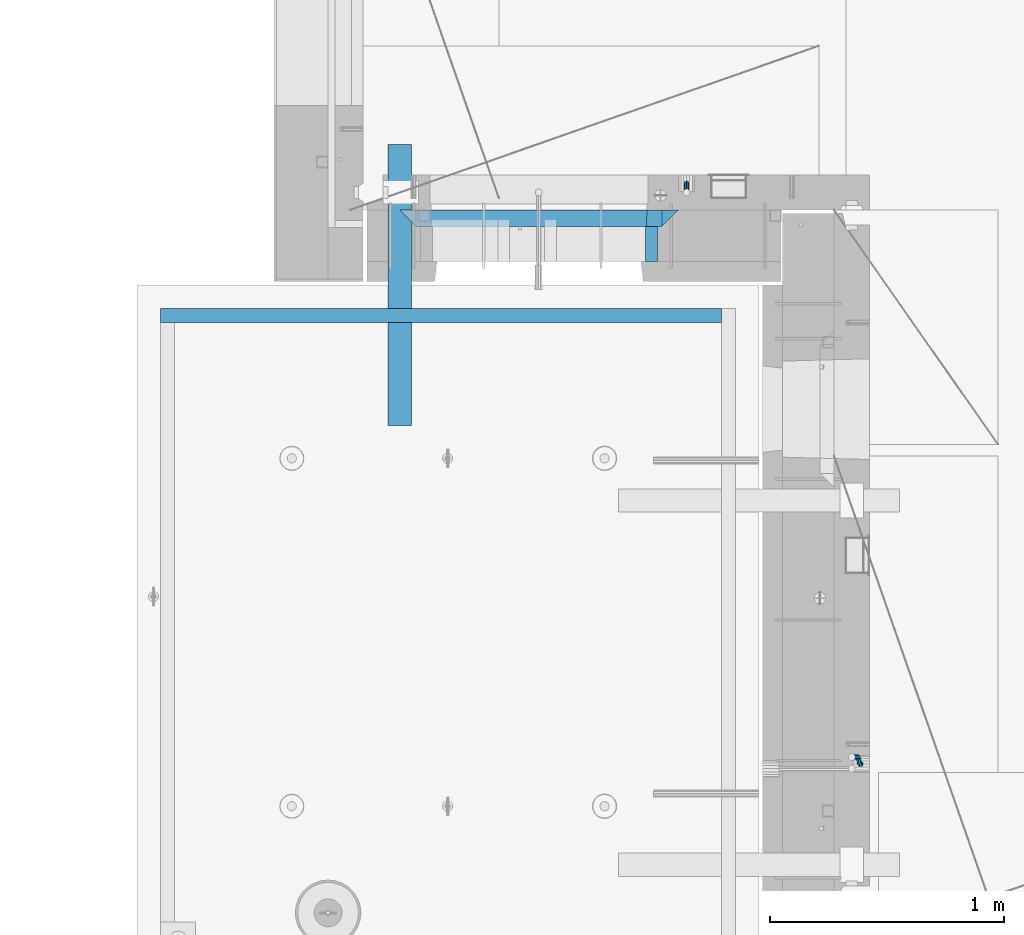
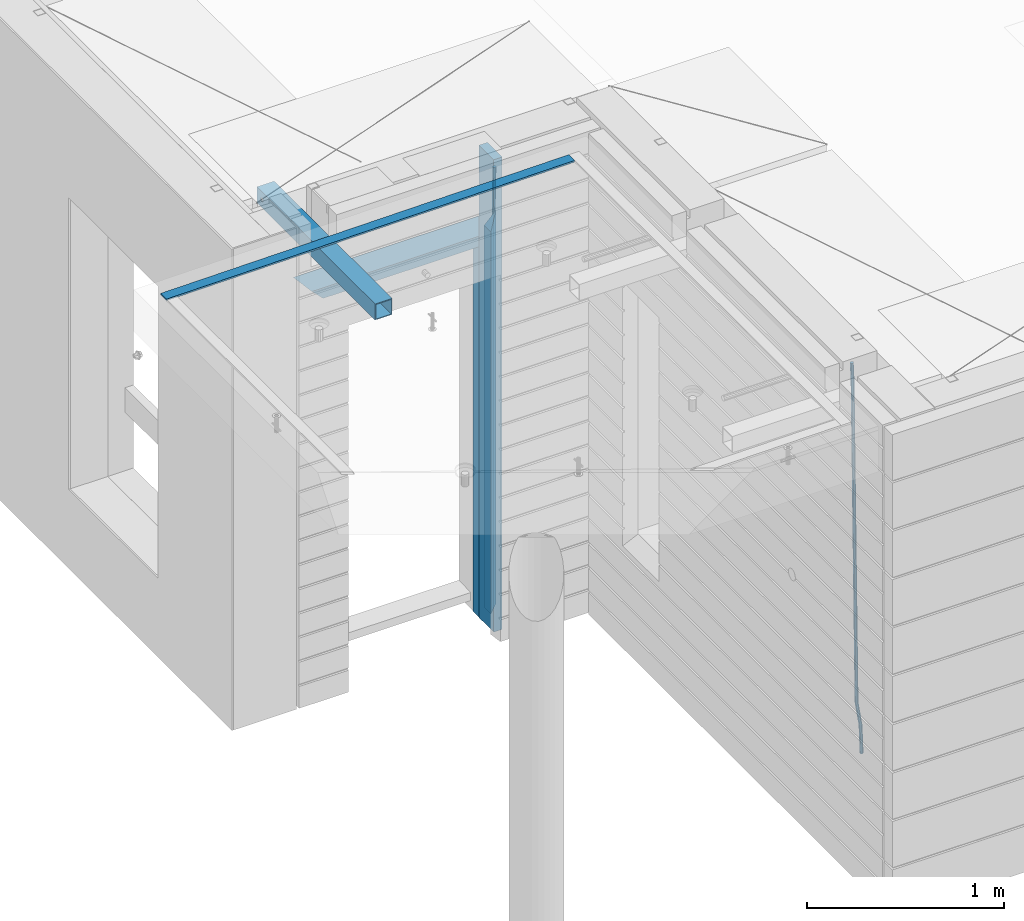
# One storey, part 88 of 334: 9 beams, 4 elements without a shape of their own.
"""IFC2X3 building model written with IfcOpenShell, lengths in millimetres."""

from ifc_helpers import new_model, si_unit, frame, origin_with_axes, place, context, subcontext, project, spatial, faceted_brep, material, type_object, element, aggregate, save


model = new_model("IFC2X3")

# Units and contexts
model_context = context("Model", 3, precision=1e-05, world=origin_with_axes())
body_context = subcontext(model_context, "Body", "Model", "MODEL_VIEW")
ifc_project = project(units=[si_unit("LENGTHUNIT", "METRE", prefix="MILLI"), si_unit("AREAUNIT", "SQUARE_METRE"), si_unit("VOLUMEUNIT", "CUBIC_METRE"), si_unit("MASSUNIT", "GRAM", prefix="KILO"), si_unit("TIMEUNIT", "SECOND"), si_unit("PLANEANGLEUNIT", "RADIAN"), si_unit("SOLIDANGLEUNIT", "STERADIAN"), si_unit("THERMODYNAMICTEMPERATUREUNIT", "DEGREE_CELSIUS"), si_unit("LUMINOUSINTENSITYUNIT", "LUMEN")], contexts=[model_context])

# Site, building, storey
site_placement = place(None, origin_with_axes())
site = spatial("IfcSite", under=ifc_project, at=site_placement, CompositionType="ELEMENT")
building_placement = place(site_placement, origin_with_axes())
building = spatial("IfcBuilding", under=site, at=building_placement, CompositionType="ELEMENT")
storey_placement = place(building_placement, origin_with_axes())
storey = spatial("IfcBuildingStorey", under=building, at=storey_placement, Name="3", CompositionType="ELEMENT", Elevation=0.0)

# Assembly, beams
assembly_1_placement = place(storey_placement, origin_with_axes())
assembly_1 = element("IfcElementAssembly", 1, at=assembly_1_placement, inside=storey, AssemblyPlace="NOTDEFINED", PredefinedType="REINFORCEMENT_UNIT")
ifc_material_1 = material(Name="CONCRETE/C25/30")
beam_type_1 = type_object("IfcBeamType", PredefinedType="NOTDEFINED")
beam_1_placement = place(assembly_1_placement, frame((8155.00084638596, 10914.9999977209, 90160.0), z_axis=(0.0, 0.0, -1.0), x_axis=(1.0, 0.0, 0.0)))
beam_1 = element("IfcBeam", 2, at=beam_1_placement, type_object=beam_type_1, material=ifc_material_1, Name="SK", context=body_context, shape_type="Brep", body=[
    faceted_brep([(70.0000000000164, -35.0, 35.0), (70.0000000000164, 35.0, 35.0), (0.0, -35.0, -35.0), (1189.99771118164, -35.0, -35.0), (1119.99771118163, -35.0, 35.0), (1119.99771118163, 35.0, 35.0)], [[[0, 1, 2]], [[0, 2, 3, 4]], [[1, 0, 4, 5]], [[2, 1, 5, 3]], [[4, 3, 5]]]),
])
beam_2_placement = place(assembly_1_placement, frame((8225.00084638596, 10914.9999988604, 90090.0), z_axis=(0.0, 0.0, -1.0), x_axis=(1.0, 0.0, 0.0)))
beam_2 = element("IfcBeam", 3, at=beam_2_placement, type_object=beam_type_1, material=ifc_material_1, Name="SK", context=body_context, shape_type="Brep", body=[
    faceted_brep([(0.0, -35.0, -35.0), (64.051765297294, -34.9999988604341, 29.0540541156515), (65.9436571275874, 34.9999988604341, 30.9459459459467), (0.0, 35.0, -35.0), (1049.99771118164, -34.9999988604341, -35.0), (985.943657065987, -34.9999988604341, 29.0540541156515), (984.051765235694, 34.9999988604341, 30.9459459459467), (1049.99771118164, 34.9999988604341, -35.0)], [[[0, 1, 2, 3]], [[1, 0, 4, 5]], [[2, 1, 5, 6]], [[3, 2, 6, 7]], [[0, 3, 7, 4]], [[6, 5, 4, 7]]]),
])
beam_3_placement = place(assembly_1_placement, frame((9309.9985575676, 10914.9999977209, 90195.0), z_axis=(-1.0, 3.00000001838171e-08, 0.0), x_axis=(0.0, 0.0, -1.0)))
beam_3 = element("IfcBeam", 4, at=beam_3_placement, type_object=beam_type_1, material=ifc_material_1, Name="SK", context=body_context, shape_type="Brep", body=[
    faceted_brep([(2440.0, -35.0, 35.0), (2440.0, -35.0, -35.0), (2440.0, 35.0, 35.0), (0.0, -35.0, -35.0), (70.0000000000164, 35.0, 35.0), (70.0000000000164, -35.0, 35.0)], [[[0, 1, 2]], [[2, 1, 3, 4]], [[0, 2, 4, 5]], [[1, 0, 5, 3]], [[5, 4, 3]]]),
])
beam_4_placement = place(assembly_1_placement, frame((9239.9985575676, 10914.9999988604, 90125.0), z_axis=(-1.0, 3.00000001838171e-08, 0.0), x_axis=(0.0, 0.0, -1.0)))
beam_4 = element("IfcBeam", 5, at=beam_4_placement, type_object=beam_type_1, material=ifc_material_1, Name="SK", context=body_context, shape_type="Brep", body=[
    faceted_brep([(2370.0, -34.9999988604341, -35.0), (2370.0, 34.9999988604341, -35.0), (2370.0, 34.9999988604341, 30.9459459459467), (2370.0, -34.9999988604341, 29.0540541156515), (0.0, -35.0, -35.0), (0.0, 35.0, -35.0), (65.9459459459467, 34.9999988604341, 30.9459459459467), (64.0540541156515, -34.9999988604341, 29.0540541156533)], [[[0, 1, 2, 3]], [[4, 5, 1, 0]], [[2, 1, 5, 6]], [[3, 2, 6, 7]], [[0, 3, 7, 4]], [[6, 5, 4, 7]]]),
])
ifc_material_2 = material(Name="TIMBER")
beam_type_2 = type_object("IfcBeamType", Name="50X150", PredefinedType="NOTDEFINED")
beam_5_placement = place(assembly_1_placement, frame((9229.9985575676, 10804.9999977209, 90690.0), z_axis=(-1.0, 3.00000001838171e-08, 0.0), x_axis=(0.0, 0.0, -1.0)))
beam_5 = element("IfcBeam", 6, at=beam_5_placement, type_object=beam_type_2, material=ifc_material_2, ObjectType="50X150", context=body_context, shape_type="Brep", body=[
    faceted_brep([(0.0, 75.0, -25.0), (1.81898940354586e-12, 75.0, 25.0), (2930.0, 75.0, 25.0), (2930.0, 75.0, -25.0), (1.81898940354586e-12, -75.0000000000009, 25.0), (2930.0, -75.0, 25.0), (0.0, -75.0, -25.0), (2930.0, -75.0, -25.0)], [[[0, 1, 2, 3]], [[1, 4, 5, 2]], [[4, 6, 7, 5]], [[6, 0, 3, 7]], [[5, 7, 3, 2]], [[6, 4, 1, 0]]]),
])
ifc_material_3 = material()
beam_type_3 = type_object("IfcBeamType", Name="D20", PredefinedType="NOTDEFINED")
beam_6_placement = place(assembly_1_placement, frame((9379.9982799665, 11065.0, 88790.0), z_axis=(0.00020576299992186, -0.999642804629538, -0.0267249099901004), x_axis=(-4.30000201928125e-08, -0.0267249099948059, 0.999642825806181)))
beam_6 = element("IfcBeam", 7, at=beam_6_placement, type_object=beam_type_3, material=ifc_material_3, Name="JM20", ObjectType="D20", context=body_context, shape_type="Brep", body=[
    faceted_brep([(0.0, -10.0, 0.0), (-4.19531716033816e-08, -7.07106781186667, -7.07106781187031), (60.4266690400545, -7.0710677960451, -7.07106780570757), (60.4266690441291, -9.99999998418934, 6.15546014159918e-09), (0.0, 0.0, -10.0), (60.426669036824, 1.58106558956206e-08, -9.99999999384454), (4.196772351861e-08, 7.07106781186303, -7.07106781186667), (60.4266690363438, 7.07106782768096, -7.07106780570757), (0.0, 10.0, 0.0), (60.4266690388904, 10.0000000158179, 6.15182216279209e-09), (4.196772351861e-08, 7.07106781185939, 7.07106781185939), (60.4266690429649, 7.07106782768096, 7.07106781802577), (0.0, 0.0, 10.0), (60.4266690461809, 1.58179318532348e-08, 10.0000000061555), (-4.19531716033816e-08, -7.07106781187031, 7.07106781185939), (60.4266690466611, -7.07106779605238, 7.07106781802213), (61.0378400410118, -7.07106779588503, -7.07106780564936), (60.991799419251, -9.99999998403655, 6.21366780251265e-09), (61.0569027789461, 1.5985278878361e-08, -9.99999999378269), (61.0378209396877, 7.07106782784831, -7.07106780564936), (60.9917724058905, 10.0000000159635, 6.21366780251265e-09), (60.9457317841297, 7.07106782781193, 7.0710678180767), (60.9266690461809, 1.59488990902901e-08, 10.0000000062028), (60.9457508854539, -7.07106779591413, 7.0710678180767), (61.6489592143771, -7.07106614513759, -7.06310863441468), (61.5568818710308, -9.9999984576425, 0.00735959856683621), (61.6870830769039, 1.71821739058942e-06, -9.99179257185824), (61.6489210170112, 7.07106947854481, -7.06310888312146), (61.556827851804, 10.0000015422847, 0.00735924683976918), (61.4647505084577, 7.07106922979438, 7.07782747982128), (61.4266266459163, 1.36643211590126e-06, 10.0065114172685), (61.464788705809, -7.07106639389531, 7.07782772852806), (176.543135720174, -7.07075579406956, -5.56673531796696), (176.451058376813, -9.99968810657447, 1.50373291501455), (176.581259582701, 0.000312069292704109, -8.49541925541052), (176.543097522794, 7.07137982961285, -5.56673556667374), (176.451004357587, 10.00031189336, 1.50373256329476), (176.35892701424, 7.07137958085514, 8.57420079627263), (176.320803151699, 0.000311717507429421, 11.5028847337162), (176.358965211621, -7.07075604281999, 8.57420104497578), (177.098753836006, -7.07075429323595, -5.55949898843028), (176.98362511232, -9.99968666800123, 1.510669025065), (177.146421932586, 0.000313595905026887, -8.48805862247536), (177.098706077581, 7.07138133041735, -5.55949936166144), (176.983557571715, 10.0003133318824, 1.51066849724157), (176.868428848029, 7.07138095712435, 8.58083651073321), (176.820760751449, 0.000313067976094317, 11.5093961447819), (176.868476606425, -7.07075466652896, 8.58083688396073), (177.654312950661, -7.07075204110879, -5.54863964998367), (177.516135294456, -9.99968450931192, 1.52107783331303), (177.711524267797, 0.000315886711177882, -8.47701274570863), (177.654255632195, 7.07138358250813, -5.54864021007961), (177.516054233929, 10.0003154905207, 1.5210770412159), (177.377876577739, 7.0713830223176, 8.59079452451624), (177.320665260588, 0.000315094497636892, 11.5191676202448), (177.377933896176, -7.07075260129932, 8.59079508461218), (299.475681513461, -7.07025820503441, -3.16743615469204), (299.337503857227, -9.99919067323572, 3.9022813287429), (299.532892830684, 0.000809722789199441, -6.09580925047521), (299.475624195184, 7.0718774185807, -3.16743671478434), (299.337422796933, 10.0008093266006, 3.9022805366476), (299.199245140699, 7.07187685839926, 10.9719980200825), (299.142033823475, 0.000808930573839461, 13.9003711158675), (299.199302458976, -7.07025876521584, 10.9719985801767), (300.014932281207, -7.07025601902387, -3.15689559088241), (299.971788958996, -9.99918809853989, 3.91467979818117), (300.032797339853, 0.000811749296190101, -6.08603777550707), (300.014914236686, 7.07187960474585, -3.15689538330298), (299.971753863239, 10.0008119014747, 3.91467990454839), (299.928610539675, 7.07187981509378, 10.9862546943223), (299.910745481058, 0.000812046770079178, 13.9153968789487), (299.92862858421, -7.07025580868321, 10.9862544867447), (300.554271526576, -7.07025682891253, -3.16085443148222), (300.606168552113, -9.999189054608, 3.91002291708173), (300.532783870876, 0.00081099850103783, -6.08970776057868), (300.554292762245, 7.0718787948008, -3.16085451222716), (300.606198583846, 10.0008109453684, 3.9100228028874), (300.658095609382, 7.07187871967653, 10.9809001514495), (300.679583265097, 0.000810892259323737, 13.9097534805496), (300.658074373729, -7.07025690404043, 10.9809002321963), (1493.73308072364, -7.07204854080373, -11.9189871896033), (1493.78497774916, -10.0009807664974, -4.84810984104297), (1493.71159306791, -0.000980713386525167, -14.8478405187034), (1493.7331019593, 7.07008708290959, -11.9189872703519), (1493.7850077809, 9.99901923348079, -4.84810995523549), (1493.83690480642, 7.07008700778533, 2.22276739332847), (1493.85839246215, -0.000980819630058249, 5.15162072242492), (1493.83688357078, -7.07204861592982, 2.22276747407341), (1494.37906755973, -7.07204951083804, -11.9237288414206), (1494.33887067712, -10.0009815982412, -4.85217550811467), (1494.43391396098, -0.000981798046268523, -14.853142475311), (1494.47128160285, 7.07008597443928, -11.9244056328516), (1494.46928102754, 9.99901820595551, -4.85313263573335), (1494.42908414494, 7.07008611855053, 2.2184206975744), (1494.37423774367, -0.000981594239419792, 5.14783433146476), (1494.3368701018, -7.07204936672315, 2.21909748900362), (1495.02495968822, -7.08047207584605, -11.9151326558385), (1494.89268239928, -10.0082034159841, -4.84480482169238), (1495.15612895518, -0.0103996287834889, -14.8435305078528), (1495.20935302251, 7.06046137268277, -11.9145826320491), (1495.15345395346, 9.99009645154365, -4.84402697058613), (1495.02117666451, 7.06236511140742, 2.22630086356003), (1494.89000739757, -0.0077073356587789, 5.15469871557252), (1494.83678333023, -7.07856833711958, 2.22575083976881), (1516.81232084993, -7.36458370639957, -11.6251644217427), (1516.68004356099, -10.292315046534, -4.55483658759658), (1516.94349011689, -0.294511259335195, -14.5535622737552), (1516.99671418422, 6.77634974212924, -11.6246143979515), (1516.94081511517, 9.70598482099194, -4.55405873649033), (1516.80853782622, 6.77825348085389, 2.51626909765582), (1516.67736855928, -0.291818966210485, 5.44466694967014), (1516.62414449194, -7.36267996767492, 2.51571907386642), (1517.44776642873, -7.37287004627251, -11.6167072694061), (1517.34013338278, -10.3009227523598, -4.54605144475318), (1517.52181307798, -0.302052708628253, -14.5458653669793), (1517.51889780765, 6.76954036124152, -11.6176646502499), (1517.44072834359, 9.69946585059188, -4.54740538572696), (1517.33309529764, 6.77141314450637, 2.52325043892597), (1517.2590486484, -0.299404193137889, 5.45240853650103), (1517.26196391872, -7.37099726300949, 2.52420781977162), (1518.08326583009, -7.37099400012448, -11.6084451566603), (1518.00027896308, -10.2989541927, -4.53746177004541), (1518.10018527637, -0.300354896351564, -14.5383632714329), (1518.04112611974, 6.77107862627236, -11.610909819372), (1517.9406844132, 9.70095671561285, -4.54094732948215), (1517.85769754619, 6.77299652303554, 2.53003605713457), (1517.84077809991, -0.297642580735555, 5.45995417190716), (1517.89983725653, -7.36907610336129, 2.53250071984621), (1618.10405127065, -7.07273188347062, -10.3110710264427), (1618.02106440364, -10.0006920760461, -3.24008763982602), (1618.12097071693, -0.00209277969770483, -13.2409891412153), (1618.06191156032, 7.06934074292622, -10.3135356891544), (1617.96146985376, 9.99921883226671, -3.24357319926276), (1617.87848298675, 7.07125863968758, 3.82741018735396), (1617.86156354047, 0.000619535918303882, 6.75732830212473), (1617.92062269709, -7.07081398670744, 3.82987485006379)], [[[0, 1, 2, 3]], [[1, 4, 5, 2]], [[4, 6, 7, 5]], [[6, 8, 9, 7]], [[8, 10, 11, 9]], [[10, 12, 13, 11]], [[12, 14, 15, 13]], [[14, 0, 3, 15]], [[14, 12, 10, 8, 6, 4, 1, 0]], [[3, 2, 16, 17]], [[2, 5, 18, 16]], [[5, 7, 19, 18]], [[7, 9, 20, 19]], [[9, 11, 21, 20]], [[11, 13, 22, 21]], [[13, 15, 23, 22]], [[15, 3, 17, 23]], [[17, 16, 24, 25]], [[16, 18, 26, 24]], [[18, 19, 27, 26]], [[19, 20, 28, 27]], [[20, 21, 29, 28]], [[21, 22, 30, 29]], [[22, 23, 31, 30]], [[23, 17, 25, 31]], [[25, 24, 32, 33]], [[24, 26, 34, 32]], [[26, 27, 35, 34]], [[27, 28, 36, 35]], [[28, 29, 37, 36]], [[29, 30, 38, 37]], [[30, 31, 39, 38]], [[31, 25, 33, 39]], [[33, 32, 40, 41]], [[32, 34, 42, 40]], [[34, 35, 43, 42]], [[35, 36, 44, 43]], [[36, 37, 45, 44]], [[37, 38, 46, 45]], [[38, 39, 47, 46]], [[39, 33, 41, 47]], [[41, 40, 48, 49]], [[40, 42, 50, 48]], [[42, 43, 51, 50]], [[43, 44, 52, 51]], [[44, 45, 53, 52]], [[45, 46, 54, 53]], [[46, 47, 55, 54]], [[47, 41, 49, 55]], [[49, 48, 56, 57]], [[48, 50, 58, 56]], [[50, 51, 59, 58]], [[51, 52, 60, 59]], [[52, 53, 61, 60]], [[53, 54, 62, 61]], [[54, 55, 63, 62]], [[55, 49, 57, 63]], [[57, 56, 64, 65]], [[56, 58, 66, 64]], [[58, 59, 67, 66]], [[59, 60, 68, 67]], [[60, 61, 69, 68]], [[61, 62, 70, 69]], [[62, 63, 71, 70]], [[63, 57, 65, 71]], [[65, 64, 72, 73]], [[64, 66, 74, 72]], [[66, 67, 75, 74]], [[67, 68, 76, 75]], [[68, 69, 77, 76]], [[69, 70, 78, 77]], [[70, 71, 79, 78]], [[71, 65, 73, 79]], [[73, 72, 80, 81]], [[72, 74, 82, 80]], [[74, 75, 83, 82]], [[75, 76, 84, 83]], [[76, 77, 85, 84]], [[77, 78, 86, 85]], [[78, 79, 87, 86]], [[79, 73, 81, 87]], [[81, 80, 88, 89]], [[80, 82, 90, 88]], [[82, 83, 91, 90]], [[83, 84, 92, 91]], [[84, 85, 93, 92]], [[85, 86, 94, 93]], [[86, 87, 95, 94]], [[87, 81, 89, 95]], [[89, 88, 96, 97]], [[88, 90, 98, 96]], [[90, 91, 99, 98]], [[91, 92, 100, 99]], [[92, 93, 101, 100]], [[93, 94, 102, 101]], [[94, 95, 103, 102]], [[95, 89, 97, 103]], [[97, 96, 104, 105]], [[96, 98, 106, 104]], [[98, 99, 107, 106]], [[99, 100, 108, 107]], [[100, 101, 109, 108]], [[101, 102, 110, 109]], [[102, 103, 111, 110]], [[103, 97, 105, 111]], [[105, 104, 112, 113]], [[104, 106, 114, 112]], [[106, 107, 115, 114]], [[107, 108, 116, 115]], [[108, 109, 117, 116]], [[109, 110, 118, 117]], [[110, 111, 119, 118]], [[111, 105, 113, 119]], [[113, 112, 120, 121]], [[112, 114, 122, 120]], [[114, 115, 123, 122]], [[115, 116, 124, 123]], [[116, 117, 125, 124]], [[117, 118, 126, 125]], [[118, 119, 127, 126]], [[119, 113, 121, 127]], [[121, 120, 128, 129]], [[120, 122, 130, 128]], [[122, 123, 131, 130]], [[123, 124, 132, 131]], [[124, 125, 133, 132]], [[125, 126, 134, 133]], [[126, 127, 135, 134]], [[127, 121, 129, 135]], [[130, 131, 132, 133, 134, 135, 129, 128]]]),
])
aggregate(assembly_1, [beam_6, beam_1, beam_2, beam_3, beam_4, beam_5])

# Assembly, beam
assembly_2_placement = place(storey_placement, origin_with_axes())
assembly_2 = element("IfcElementAssembly", 8, at=assembly_2_placement, inside=storey, AssemblyPlace="NOTDEFINED", PredefinedType="REINFORCEMENT_UNIT")
beam_7_placement = place(assembly_2_placement, frame((10125.0000000031, 8585.0017200335, 87989.9999999969), z_axis=(-0.999642804636942, -0.000205726999925762, -0.0267249099902983), x_axis=(-0.0267249099948371, 4.30000201934385e-08, 0.999642825806181)))
beam_7 = element("IfcBeam", 9, at=beam_7_placement, type_object=beam_type_3, material=ifc_material_3, Name="JM20", ObjectType="D20", context=body_context, shape_type="Brep", body=[
    faceted_brep([(0.0, -10.0, 0.0), (-4.19531716033816e-08, -7.07106781186667, -7.07106781187031), (60.4266690400545, -7.0710677960451, -7.07106780570757), (60.4266690441291, -9.99999998418934, 6.15546014159918e-09), (0.0, 0.0, -10.0), (60.426669036824, 1.58106558956206e-08, -9.99999999384454), (4.196772351861e-08, 7.07106781186303, -7.07106781186667), (60.4266690363438, 7.07106782768096, -7.07106780570757), (0.0, 10.0, 0.0), (60.4266690388904, 10.0000000158179, 6.15182216279209e-09), (4.196772351861e-08, 7.07106781185939, 7.07106781185939), (60.4266690429649, 7.07106782768096, 7.07106781802577), (0.0, 0.0, 10.0), (60.4266690461809, 1.58179318532348e-08, 10.0000000061555), (-4.19531716033816e-08, -7.07106781187031, 7.07106781185939), (60.4266690466611, -7.07106779605238, 7.07106781802213), (61.0378400410118, -7.07106779588503, -7.07106780564936), (60.991799419251, -9.99999998403655, 6.21366780251265e-09), (61.0569027789461, 1.5985278878361e-08, -9.99999999378269), (61.0378209396877, 7.07106782784831, -7.07106780564936), (60.9917724058905, 10.0000000159635, 6.21366780251265e-09), (60.9457317841297, 7.07106782781193, 7.0710678180767), (60.9266690461809, 1.59488990902901e-08, 10.0000000062028), (60.9457508854539, -7.07106779591413, 7.0710678180767), (61.6489592143771, -7.07106614513759, -7.06310863441468), (61.5568818710308, -9.9999984576425, 0.00735959856683621), (61.6870830769039, 1.71821739058942e-06, -9.99179257185824), (61.6489210170112, 7.07106947854481, -7.06310888312146), (61.556827851804, 10.0000015422847, 0.00735924683976918), (61.4647505084577, 7.07106922979438, 7.07782747982128), (61.4266266459163, 1.36643211590126e-06, 10.0065114172685), (61.464788705809, -7.07106639389531, 7.07782772852806), (175.37403592006, -7.07075895339585, -5.5819617630732), (175.281958576699, -9.99969126589349, 1.48850647000108), (175.412159782674, 0.000308909964587656, -8.51064570055678), (175.373997722811, 7.07137667028292, -5.58196201177816), (175.281904557633, 10.0003087340338, 1.48850611827766), (175.189827214257, 7.07137642153248, 8.55897435135012), (175.151703351657, 0.000308558175674989, 11.4876582888337), (175.189865411507, -7.07075920214811, 8.55897460005508), (177.947973008238, -7.07075200072177, -5.54843899804655), (178.185320525896, -9.99968342338434, 1.52631963989006), (177.145703789589, 0.000313592583552236, -8.48806815245916), (176.248471297557, 7.07137903239709, -5.57057293303842), (175.781862157353, 10.0003100845097, 1.49501752883771), (176.019209675011, 7.07137866184712, 8.56977616677796), (176.82147889366, 0.000313068545438, 11.5094053211888), (177.718711385693, -7.07075237127174, 8.59191010176619), (180.448353003565, -6.46083449902471, -5.49969035980757), (181.005711191348, -9.31170574331372, 1.58130736355633), (178.829707169425, 0.411092408678087, -8.45523599426269), (177.097954465877, 7.27859339690076, -5.55401099135815), (176.267532139987, 10.118779526354, 1.50448638970374), (176.824890327771, 7.26790828206686, 8.58548411306947), (178.443536161911, 0.395981374362236, 11.5410297475228), (180.175288865445, -6.47151961386044, 8.63980474461823), (300.130679507536, 22.7332662835124, -3.16630485466521), (300.688037695305, 19.8823950392234, 3.91469286870233), (298.512033673396, 29.6051931912152, -6.12185048911851), (296.780280969833, 36.4726941794397, -3.22062548621216), (295.949858643944, 39.312880308893, 3.83787189484792), (296.507216831713, 36.462009064604, 10.9188696182155), (298.125862665867, 29.5900821569012, 13.8744152526688), (299.85761536943, 22.7225811686749, 10.9731902497624), (300.838254221671, 22.9058649296021, -3.15250963000472), (301.173707677939, 20.0008644810696, 3.92416172956655), (299.995227641819, 29.9669885828916, -6.09293340998011), (299.138461475406, 37.0479249704349, -3.1746492391685), (298.769837722954, 40.0007575907111, 3.89285159402425), (299.105291179221, 37.0957571421768, 10.9695229535973), (299.948317759059, 30.0346334888854, 13.9099467335673), (300.805083925487, 22.9536971013422, 10.9916625627593), (301.566623170889, 22.9058626555343, -3.16352102199562), (301.673650550176, 20.0008629201784, 3.91660365485041), (301.522009776192, 29.9669838160717, -6.1160151140848), (301.565944287635, 37.0479173915064, -3.21134762509791), (301.672690464271, 40.0007485276092, 3.84896662410392), (301.779717843558, 37.0957487922533, 10.9290913009499), (301.82433123824, 30.0346276317159, 13.881585393041), (301.780396726797, 22.953694056283, 10.9769179040522), (2293.36508471855, 22.8996439899911, -33.2752846422391), (2293.47211209782, 19.9946442546316, -26.195159965393), (2293.32047132387, 29.9607651505266, -36.2277787343282), (2293.36440583531, 37.0416987259578, -33.3231112453414), (2293.47115201195, 39.9945298620642, -26.2627969961413), (2293.5781793912, 37.0895301267083, -19.1826723192917), (2293.6227927859, 30.0284089661727, -16.2301782272025), (2293.57885827446, 22.947475390738, -19.134845716193), (2294.06569143596, 22.8996418025999, -33.2858763282329), (2294.05315457586, 19.9946424405407, -26.2039440939534), (2294.10906780435, 29.9607626884226, -36.2397006387127), (2294.15787439278, 37.0416962486433, -33.3351068051852), (2294.18352096362, 39.9945276379531, -26.2735665021428), (2294.17098410353, 37.089528275892, -19.1916342678614), (2294.12760773512, 30.0284073900693, -16.2378099573798), (2294.07880114671, 22.9474738298504, -19.1424037909092), (2294.76625661059, 22.8905062380709, -33.2765524984534), (2294.63416260075, 19.9870659344633, -26.1962114516227), (2294.89761752472, 29.9504797809677, -36.2292058216281), (2294.95129590121, 37.0313498117212, -33.3245471494174), (2294.8958476751, 39.9852386997136, -26.2640861379368), (2294.76375366526, 37.0817983961042, -19.1837450911044), (2294.63239275114, 30.0218248532074, -16.2310917679315), (2294.57871437464, 22.9409548224558, -19.135750440144), (2316.52593703129, 22.6067539594387, -32.9869526673174), (2316.39384302145, 19.7033136558293, -25.9066116204867), (2316.65729794541, 29.6667275023337, -35.9396059904902), (2316.71097632191, 36.7475975330854, -33.0349473182796), (2316.6555280958, 39.7014864210796, -25.974486306799), (2316.52343408595, 36.798046117472, -18.8941452599665), (2316.39207317181, 29.7380725745734, -15.9414919367919), (2316.33839479534, 22.6572025438199, -18.8461506090043), (2317.16158675382, 22.5984649104412, -32.9784927980199), (2317.05394423746, 19.6947057525631, -25.8978263259869), (2317.23590155228, 29.6591823505332, -35.931905348587), (2317.23335603178, 36.740785556527, -33.0279949608521), (2317.15544132373, 39.6949674136868, -25.967832956032), (2317.04779880737, 36.7912082558087, -18.887166483999), (2316.97348400892, 29.730490815713, -15.9337539334319), (2316.97602952941, 22.648887609721, -18.8376643211668), (2317.79729034709, 22.6003447382427, -32.9702310967514), (2317.71410127044, 19.6966744277033, -25.8892409069249), (2317.81455440674, 29.660885407864, -35.9243995360212), (2317.75578039732, 36.7423274699941, -33.021234418542), (2317.65539733646, 39.6964582057935, -25.9613704963267), (2317.57220825978, 36.7927878952578, -18.8803803065002), (2317.55494420015, 29.7322472256365, -15.9262118672305), (2317.6137182096, 22.6508051635028, -18.8293769847114), (2417.81807008978, 22.8986075784269, -31.6728570405921), (2417.73488101311, 19.9949372678893, -24.5918668507657), (2417.83533414939, 29.9591482480482, -34.6270254798619), (2417.77656013996, 37.0405903101819, -31.7238603623846), (2417.67617707912, 39.9947210459814, -24.6639964401675), (2417.59298800245, 37.0910507354438, -17.5830062503428), (2417.57572394283, 30.0305100658206, -14.628837811073), (2417.63449795225, 22.9490680036906, -17.5320029285504)], [[[0, 1, 2, 3]], [[1, 4, 5, 2]], [[4, 6, 7, 5]], [[6, 8, 9, 7]], [[8, 10, 11, 9]], [[10, 12, 13, 11]], [[12, 14, 15, 13]], [[14, 0, 3, 15]], [[14, 12, 10, 8, 6, 4, 1, 0]], [[3, 2, 16, 17]], [[2, 5, 18, 16]], [[5, 7, 19, 18]], [[7, 9, 20, 19]], [[9, 11, 21, 20]], [[11, 13, 22, 21]], [[13, 15, 23, 22]], [[15, 3, 17, 23]], [[17, 16, 24, 25]], [[16, 18, 26, 24]], [[18, 19, 27, 26]], [[19, 20, 28, 27]], [[20, 21, 29, 28]], [[21, 22, 30, 29]], [[22, 23, 31, 30]], [[23, 17, 25, 31]], [[25, 24, 32, 33]], [[24, 26, 34, 32]], [[26, 27, 35, 34]], [[27, 28, 36, 35]], [[28, 29, 37, 36]], [[29, 30, 38, 37]], [[30, 31, 39, 38]], [[31, 25, 33, 39]], [[33, 32, 40, 41]], [[32, 34, 42, 40]], [[34, 35, 43, 42]], [[35, 36, 44, 43]], [[36, 37, 45, 44]], [[37, 38, 46, 45]], [[38, 39, 47, 46]], [[39, 33, 41, 47]], [[41, 40, 48, 49]], [[40, 42, 50, 48]], [[42, 43, 51, 50]], [[43, 44, 52, 51]], [[44, 45, 53, 52]], [[45, 46, 54, 53]], [[46, 47, 55, 54]], [[47, 41, 49, 55]], [[49, 48, 56, 57]], [[48, 50, 58, 56]], [[50, 51, 59, 58]], [[51, 52, 60, 59]], [[52, 53, 61, 60]], [[53, 54, 62, 61]], [[54, 55, 63, 62]], [[55, 49, 57, 63]], [[57, 56, 64, 65]], [[56, 58, 66, 64]], [[58, 59, 67, 66]], [[59, 60, 68, 67]], [[60, 61, 69, 68]], [[61, 62, 70, 69]], [[62, 63, 71, 70]], [[63, 57, 65, 71]], [[65, 64, 72, 73]], [[64, 66, 74, 72]], [[66, 67, 75, 74]], [[67, 68, 76, 75]], [[68, 69, 77, 76]], [[69, 70, 78, 77]], [[70, 71, 79, 78]], [[71, 65, 73, 79]], [[73, 72, 80, 81]], [[72, 74, 82, 80]], [[74, 75, 83, 82]], [[75, 76, 84, 83]], [[76, 77, 85, 84]], [[77, 78, 86, 85]], [[78, 79, 87, 86]], [[79, 73, 81, 87]], [[81, 80, 88, 89]], [[80, 82, 90, 88]], [[82, 83, 91, 90]], [[83, 84, 92, 91]], [[84, 85, 93, 92]], [[85, 86, 94, 93]], [[86, 87, 95, 94]], [[87, 81, 89, 95]], [[89, 88, 96, 97]], [[88, 90, 98, 96]], [[90, 91, 99, 98]], [[91, 92, 100, 99]], [[92, 93, 101, 100]], [[93, 94, 102, 101]], [[94, 95, 103, 102]], [[95, 89, 97, 103]], [[97, 96, 104, 105]], [[96, 98, 106, 104]], [[98, 99, 107, 106]], [[99, 100, 108, 107]], [[100, 101, 109, 108]], [[101, 102, 110, 109]], [[102, 103, 111, 110]], [[103, 97, 105, 111]], [[105, 104, 112, 113]], [[104, 106, 114, 112]], [[106, 107, 115, 114]], [[107, 108, 116, 115]], [[108, 109, 117, 116]], [[109, 110, 118, 117]], [[110, 111, 119, 118]], [[111, 105, 113, 119]], [[113, 112, 120, 121]], [[112, 114, 122, 120]], [[114, 115, 123, 122]], [[115, 116, 124, 123]], [[116, 117, 125, 124]], [[117, 118, 126, 125]], [[118, 119, 127, 126]], [[119, 113, 121, 127]], [[121, 120, 128, 129]], [[120, 122, 130, 128]], [[122, 123, 131, 130]], [[123, 124, 132, 131]], [[124, 125, 133, 132]], [[125, 126, 134, 133]], [[126, 127, 135, 134]], [[127, 121, 129, 135]], [[130, 131, 132, 133, 134, 135, 129, 128]]]),
])
aggregate(assembly_2, [beam_7])

# Assemblies, beams
assembly_3_placement = place(storey_placement, origin_with_axes())
assembly_3 = element("IfcElementAssembly", 10, at=assembly_3_placement, inside=storey, AssemblyPlace="NOTDEFINED", PredefinedType="REINFORCEMENT_UNIT")
assembly_4_placement = place(assembly_3_placement, origin_with_axes())
assembly_4 = element("IfcElementAssembly", 11, at=assembly_4_placement, AssemblyPlace="NOTDEFINED", PredefinedType="NOTDEFINED")
ifc_material_4 = material(Name="Undefined/350")
beam_type_4 = type_object("IfcBeamType", Name="100X100X5", PredefinedType="NOTDEFINED")
beam_8_placement = place(assembly_4_placement, frame((8154.95985679893, 10029.9865573969, 90555.0), z_axis=(0.0, 0.0, 1.0), x_axis=(2.22429999942101e-05, 0.999999999752625, 0.0)))
beam_8 = element("IfcBeam", 12, at=beam_8_placement, type_object=beam_type_4, material=ifc_material_4, ObjectType="100X100X5", context=body_context, shape_type="Brep", body=[
    faceted_brep([(1160.82642950046, -49.9743978761207, -6.25), (1160.82642783901, -44.9999999999991, -6.25), (1156.25111029171, -44.9999999999991, -10.8253175473074), (1156.25111195316, -49.9743994042774, -10.8253175473074), (1150.00111029171, -44.9999999999991, -12.5), (1150.00111195316, -49.9744014917787, -12.5), (1143.75111029171, -44.9999999999991, -10.8253175473074), (1143.75111195316, -49.9744035792783, -10.8253175473074), (1139.1757927444, -44.9999999999991, -6.25), (1139.17579440585, -49.9744051074349, -6.25), (1137.50111029171, -44.9999999999991, 0.0), (1137.50111195316, -49.9744056667778, 0.0), (1139.1757927444, -44.9999999999991, 6.25), (1139.17579440585, -49.9744051074349, 6.25), (1143.75111029171, -44.9999999999991, 10.8253175473074), (1143.75111195316, -49.9744035792783, 10.8253175473074), (1150.00111029171, -44.9999999999991, 12.5), (1150.00111195316, -49.9744014917787, 12.5), (1156.25111029171, -44.9999999999991, 10.8253175473074), (1156.25111195316, -49.9743994042774, 10.8253175473074), (1160.82642783901, -44.9999999999991, 6.25), (1160.82642950046, -49.9743978761207, 6.25), (1162.50111029171, -44.9999999999991, 0.0), (1162.50111195316, -49.9743973167779, 0.0), (1160.82639777901, 44.9999999999982, -6.25), (1160.82639610046, 50.0256021227788, -6.25), (1156.25107855315, 50.0256005946221, -10.8253175473074), (1156.2510802317, 44.9999999999982, -10.8253175473074), (1150.00107855316, 50.0255985071226, -12.5), (1150.00108023171, 44.9999999999982, -12.5), (1143.75107855316, 50.0255964196231, -10.8253175473074), (1143.75108023171, 44.9999999999982, -10.8253175473074), (1139.17576100585, 50.0255948914664, -6.25), (1139.1757626844, 44.9999999999982, -6.25), (1137.50107855316, 50.0255943321226, 0.0), (1137.5010802317, 44.9999999999982, 0.0), (1139.17576100585, 50.0255948914664, 6.25), (1139.1757626844, 44.9999999999982, 6.25), (1143.75107855316, 50.0255964196231, 10.8253175473074), (1143.75108023171, 44.9999999999982, 10.8253175473074), (1150.00107855316, 50.0255985071226, 12.5), (1150.00108023171, 44.9999999999982, 12.5), (1156.25107855315, 50.0256005946221, 10.8253175473074), (1156.2510802317, 44.9999999999982, 10.8253175473074), (1160.82639610046, 50.0256021227788, 6.25), (1160.82639777901, 44.9999999999982, 6.25), (1162.50107855316, 50.0256026821226, 0.0), (1162.50108023171, 44.9999999999982, 0.0), (1.81898940354586e-12, -50.0000000000009, -50.0), (1.81898940354586e-12, 49.9999999999991, -50.0), (1200.00449189278, 49.9999999999982, -50.0), (1200.00449189278, -50.0000000000009, -50.0), (1.81898940354586e-12, -50.0000000000009, 50.0), (1200.00449189278, -50.0000000000009, 50.0), (1.81898940354586e-12, 49.9999999999991, 50.0), (1200.00449189278, 49.9999999999982, 50.0), (0.0, 44.9999999999991, 45.0), (1.81898940354586e-12, -45.0000000000009, 45.0), (1.81898940354586e-12, -45.0000000000009, -45.0), (0.0, 44.9999999999991, -45.0), (1200.00449189278, 44.9999999999982, -45.0), (1200.00449189278, 44.9999999999982, 45.0), (1200.00449189278, -45.0000000000009, 45.0), (1200.00449189278, -45.0000000000009, -45.0)], [[[0, 1, 2, 3]], [[3, 2, 4, 5]], [[5, 4, 6, 7]], [[7, 6, 8, 9]], [[9, 8, 10, 11]], [[11, 10, 12, 13]], [[13, 12, 14, 15]], [[15, 14, 16, 17]], [[17, 16, 18, 19]], [[19, 18, 20, 21]], [[21, 20, 22, 23]], [[23, 22, 1, 0]], [[24, 25, 26, 27]], [[27, 26, 28, 29]], [[29, 28, 30, 31]], [[31, 30, 32, 33]], [[33, 32, 34, 35]], [[35, 34, 36, 37]], [[37, 36, 38, 39]], [[39, 38, 40, 41]], [[41, 40, 42, 43]], [[43, 42, 44, 45]], [[45, 44, 46, 47]], [[47, 46, 25, 24]], [[48, 49, 50, 51]], [[52, 48, 51, 53], [3, 5, 7, 9, 11, 13, 15, 17, 19, 21, 23, 0]], [[54, 52, 53, 55]], [[48, 52, 54, 49], [56, 57, 58, 59]], [[56, 59, 60, 61], [27, 29, 31, 33, 35, 37, 39, 41, 43, 45, 47, 24]], [[57, 56, 61, 62]], [[58, 57, 62, 63], [18, 16, 14, 12, 10, 8, 6, 4, 2, 1, 22, 20]], [[59, 58, 63, 60]], [[53, 51, 50, 55], [62, 61, 60, 63]], [[49, 54, 55, 50], [42, 40, 38, 36, 34, 32, 30, 28, 26, 25, 46, 44]]]),
])
aggregate(assembly_4, [beam_8])
ifc_material_5 = material(Name="CONCRETE/Concrete_Undefined")
beam_type_5 = type_object("IfcBeamType", PredefinedType="NOTDEFINED")
beam_9_placement = place(assembly_3_placement, frame((9529.73225763201, 10500.0586098955, 90724.6636624749), z_axis=(-0.00918619300035676, -2.22000000585005e-07, 0.99995780603889), x_axis=(-0.999957805748064, -2.41189999941813e-05, -0.00918619299768504)))
beam_9 = element("IfcBeam", 13, at=beam_9_placement, type_object=beam_type_5, material=ifc_material_5, context=body_context, shape_type="Brep", body=[
    faceted_brep([(2.5465851649642e-11, 29.9999999999982, -4.99999999998545), (-2.91038304567337e-11, 29.9999999999982, 5.0), (2394.89682739776, 29.9999999999964, 5.0), (2394.89682739781, 30.0, -4.99999999998545), (-2.5465851649642e-11, -30.0000000000018, 5.0), (2394.89682739776, -30.0000000000036, 5.0), (2.72848410531878e-11, -30.0000000000018, -4.99999999998545), (2394.89682739781, -30.0, -4.99999999998545)], [[[0, 1, 2, 3]], [[1, 4, 5, 2]], [[4, 6, 7, 5]], [[6, 0, 3, 7]], [[5, 7, 3, 2]], [[6, 4, 1, 0]]]),
])
aggregate(assembly_3, [beam_9, assembly_4])

save(model, "model.ifc")
